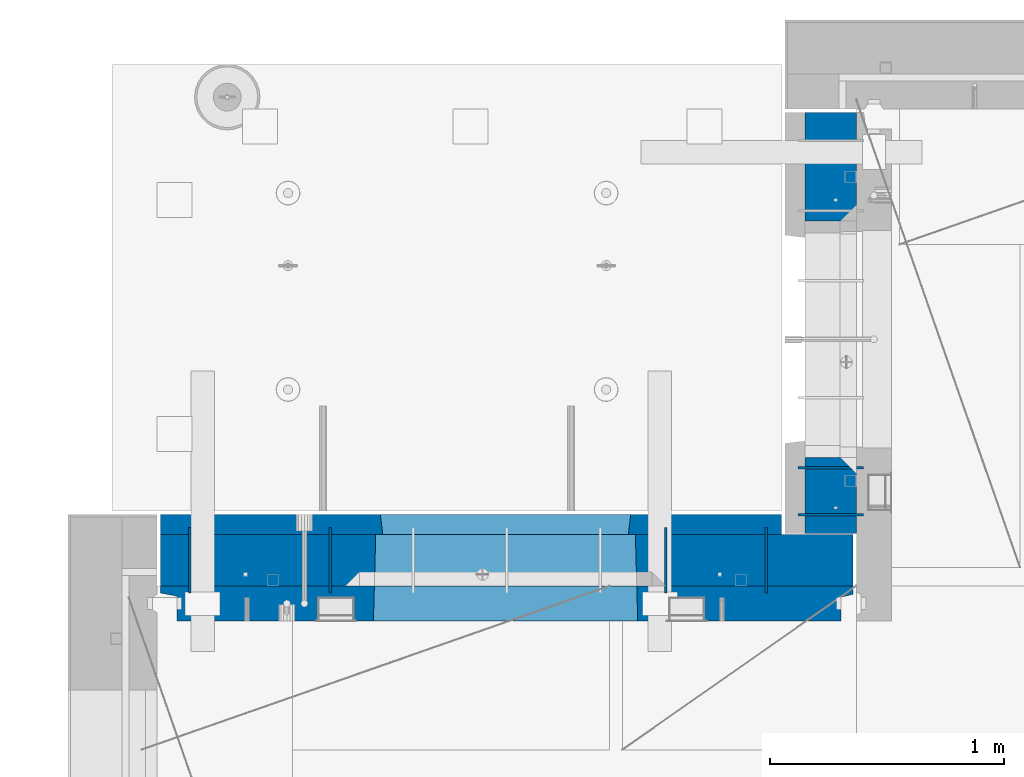
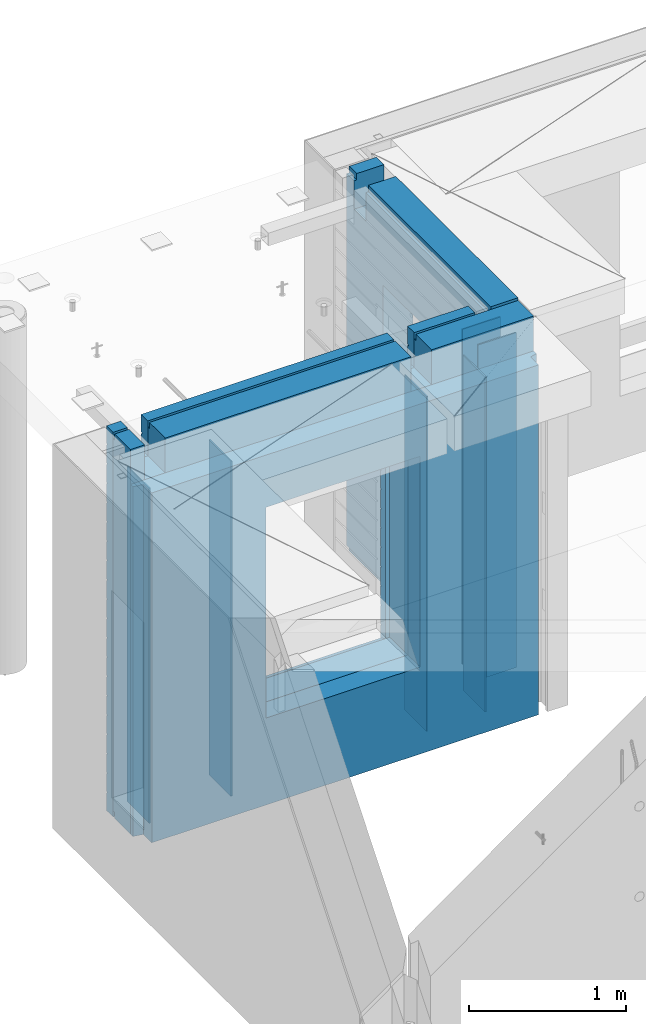
# One storey, part 201 of 309: 10 walls, 2 elements without a shape of their own.
"""IFC2X3 building model written with IfcOpenShell, lengths in millimetres."""

import ifcopenshell
import ifcopenshell.guid

model = None  # the IFC model being written
_history = None  # IfcOwnerHistory: only IFC2X3 demands one
_inside = {}  # id of a spatial element -> (the spatial element, [elements in it])
_under = {}  # id of a project, library or spatial element -> (it, [spatial elements below it])
_declared = {}  # id of a project -> (the project, [libraries it declares])
_typed = {}  # id of a type object -> (the type object, [elements of that type])
_made_of = {}  # id of a material, layer set ... -> (it, [elements and type objects made of it])


def new_model(schema):
    """Start an empty IFC model of exactly this schema.

    Asked for "IFC4X3", IfcOpenShell would pick the latest addendum, in which some entities
    have other attributes; the version numbers below select the first issue.
    IFC2X3 requires an IfcOwnerHistory on every rooted entity: one is made here for all.
    """
    global model, _history
    if schema == "IFC4X3":
        model = ifcopenshell.file(schema_version=(4, 3, 0, 0))
    else:
        model = ifcopenshell.file(schema=schema)
    _inside.clear()
    _under.clear()
    _declared.clear()
    _typed.clear()
    _made_of.clear()
    _history = None
    if model.schema == "IFC2X3":
        org = make("IfcOrganization", Name="unknown")
        user = make(
            "IfcPersonAndOrganization",
            ThePerson=make("IfcPerson", FamilyName="unknown"),
            TheOrganization=org,
        )
        app = make(
            "IfcApplication",
            ApplicationDeveloper=org,
            Version="unknown",
            ApplicationFullName="unknown",
            ApplicationIdentifier="unknown",
        )
        _history = make(
            "IfcOwnerHistory",
            OwningUser=user,
            OwningApplication=app,
            ChangeAction="ADDED",
            CreationDate=0,
        )
    return model


def make(cls, **values):
    """One entity of the class cls with the attributes given. An attribute that is None is left unset."""
    return model.create_entity(
        cls, **{name: value for name, value in values.items() if value is not None}
    )


def rooted(cls, **values):
    """An entity with a GlobalId (a new one), such as an element, a storey or a relation."""
    return make(cls, GlobalId=ifcopenshell.guid.new(), OwnerHistory=_history, **values)


def si_unit(unit_type, name, prefix=None):
    """IfcSIUnit, for example si_unit("LENGTHUNIT", "METRE", prefix="MILLI")."""
    return make("IfcSIUnit", UnitType=unit_type, Prefix=prefix, Name=name)


def assignment(units):
    """IfcUnitAssignment: the units of a project."""
    return None if units is None else make("IfcUnitAssignment", Units=units)


def point(xyz):
    """IfcCartesianPoint."""
    return None if xyz is None else make("IfcCartesianPoint", Coordinates=xyz)


def direction(xyz):
    """IfcDirection."""
    return None if xyz is None else make("IfcDirection", DirectionRatios=xyz)


def frame(location, z_axis=None, x_axis=None):
    """IfcAxis2Placement3D, a coordinate frame: its origin and axes. An axis left out is left unset."""
    return make(
        "IfcAxis2Placement3D",
        Location=point(location),
        Axis=direction(z_axis),
        RefDirection=direction(x_axis),
    )


def origin_with_axes():
    """The frame at (0, 0, 0) with the z axis (0, 0, 1) and the x axis (1, 0, 0) written out."""
    return frame((0.0, 0.0, 0.0), z_axis=(0.0, 0.0, 1.0), x_axis=(1.0, 0.0, 0.0))


def place(relative_to, where):
    """IfcLocalPlacement: puts the frame where relative to a parent placement (None: the world)."""
    return make(
        "IfcLocalPlacement", PlacementRelTo=relative_to, RelativePlacement=where
    )


def context(
    kind, dimensions, precision=None, world=None, true_north=None, identifier=None
):
    """IfcGeometricRepresentationContext, for example the 3D "Model" context."""
    return make(
        "IfcGeometricRepresentationContext",
        ContextIdentifier=identifier,
        ContextType=kind,
        CoordinateSpaceDimension=dimensions,
        Precision=precision,
        WorldCoordinateSystem=world,
        TrueNorth=true_north,
    )


def subcontext(parent, identifier, kind, view, scale=None):
    """IfcGeometricRepresentationSubContext, for example "Body" below "Model"."""
    return make(
        "IfcGeometricRepresentationSubContext",
        ContextIdentifier=identifier,
        ContextType=kind,
        ParentContext=parent,
        TargetScale=scale,
        TargetView=view,
    )


def project(units=None, contexts=None):
    """IfcProject with its units and contexts."""
    return rooted(
        "IfcProject",
        Name="project",
        RepresentationContexts=contexts,
        UnitsInContext=assignment(units),
    )


def spatial(cls, under=None, at=None, **own):
    """A site, building, storey or space (cls), placed at a placement, below another one or the project."""
    s = rooted(cls, ObjectPlacement=at, **own)
    if under is not None:
        _under.setdefault(under.id(), (under, []))[1].append(s)
    return s


def faces_of(points, faces, orient=None, outer=None):
    """IfcFace entities. A face is a list of loops; a loop is a list of indices into points, from 0.

    orient and outer hold one flag for each loop. By default every Orientation is true, the
    first loop of a face is its IfcFaceOuterBound and the others are IfcFaceBound.
    """
    made = []
    for i, loops in enumerate(faces):
        bounds = []
        for j, loop in enumerate(loops):
            is_outer = j == 0 if outer is None else outer[i][j]
            bounds.append(
                make(
                    "IfcFaceOuterBound" if is_outer else "IfcFaceBound",
                    Bound=make("IfcPolyLoop", Polygon=[points[k] for k in loop]),
                    Orientation=True if orient is None else orient[i][j],
                )
            )
        made.append(make("IfcFace", Bounds=bounds))
    return made


def faceted_brep(points, faces, orient=None, outer=None, voids=None):
    """IfcFacetedBrep: a solid bounded by flat faces; with voids (closed shells), ...WithVoids."""
    shared = [point(p) for p in points]
    hull = make("IfcClosedShell", CfsFaces=faces_of(shared, faces, orient, outer))
    if voids is None:
        return make("IfcFacetedBrep", Outer=hull)
    return make(
        "IfcFacetedBrepWithVoids",
        Outer=hull,
        Voids=[
            make(cls, CfsFaces=faces_of(shared, fs, o, b)) for cls, fs, o, b in voids
        ],
    )


def shape(context_of_items, identifier, shape_type, items):
    """IfcShapeRepresentation: the items that make up one representation, for example the "Body"."""
    return make(
        "IfcShapeRepresentation",
        ContextOfItems=context_of_items,
        RepresentationIdentifier=identifier,
        RepresentationType=shape_type,
        Items=items,
    )


def material(Name=None, Category=None):
    """IfcMaterial."""
    return make("IfcMaterial", Name=Name, Category=Category)


def made_of(thing, what):
    """Note that an element or type object is made of a material, layer set ...; save() writes the relation."""
    if what is not None:
        _made_of.setdefault(what.id(), (what, []))[1].append(thing)
    return thing


def type_object(cls, material=None, **own):
    """A type object (cls), such as IfcWallType, which elements share."""
    return made_of(rooted(cls, **own), material)


def element(
    cls,
    number,
    at=None,
    inside=None,
    cuts=None,
    type_object=None,
    material=None,
    context=None,
    identifier="Body",
    shape_type=None,
    held_by="IfcProductDefinitionShape",
    body=None,
    shapes=None,
    **own,
):
    """One element of the class cls, such as IfcWall. Its Tag is "e" and its number.

    at: its placement. inside: the storey or other place that contains it. cuts: it is an
    opening in that element (IfcRelVoidsElement). A single representation is given by context,
    identifier, shape_type and body (its items); several are given by shapes. held_by: the class
    of the entity that holds the representations. save() writes the other relations.
    """
    e = rooted(cls, Tag="e%d" % number, ObjectPlacement=at, **own)
    if body is not None:
        shapes = [shape(context, identifier, shape_type, body)]
    if shapes is not None:
        e.Representation = make(held_by, Representations=shapes)
    if inside is not None:
        _inside.setdefault(inside.id(), (inside, []))[1].append(e)
    if cuts is not None:
        rooted(
            "IfcRelVoidsElement", RelatingBuildingElement=cuts, RelatedOpeningElement=e
        )
    if type_object is not None:
        _typed.setdefault(type_object.id(), (type_object, []))[1].append(e)
    return made_of(e, material)


def aggregate(whole, parts):
    """IfcRelAggregates: a whole, such as a stair, and the parts it consists of."""
    return rooted("IfcRelAggregates", RelatingObject=whole, RelatedObjects=parts)


def save(model, path):
    """Write the relations noted so far, then the file.

    IfcRelAggregates (storeys below a building ...), IfcRelContainedInSpatialStructure (elements
    in a storey), IfcRelDefinesByType, IfcRelAssociatesMaterial and IfcRelDeclares: one each for
    every whole, place, type object, material and project.
    """
    for whole, parts in _under.values():
        aggregate(whole, parts)
    for where, things in _inside.values():
        rooted(
            "IfcRelContainedInSpatialStructure",
            RelatedElements=things,
            RelatingStructure=where,
        )
    for kind, things in _typed.values():
        rooted("IfcRelDefinesByType", RelatedObjects=things, RelatingType=kind)
    for what, things in _made_of.values():
        rooted("IfcRelAssociatesMaterial", RelatedObjects=things, RelatingMaterial=what)
    for by, libraries in _declared.values():
        rooted("IfcRelDeclares", RelatingContext=by, RelatedDefinitions=libraries)
    model.write(path)


model = new_model("IFC2X3")

# Units and contexts
model_context = context("Model", 3, precision=1e-05, world=origin_with_axes())
body_context = subcontext(model_context, "Body", "Model", "MODEL_VIEW")
ifc_project = project(units=[si_unit("LENGTHUNIT", "METRE", prefix="MILLI"), si_unit("AREAUNIT", "SQUARE_METRE"), si_unit("VOLUMEUNIT", "CUBIC_METRE"), si_unit("MASSUNIT", "GRAM", prefix="KILO"), si_unit("TIMEUNIT", "SECOND"), si_unit("PLANEANGLEUNIT", "RADIAN"), si_unit("SOLIDANGLEUNIT", "STERADIAN"), si_unit("THERMODYNAMICTEMPERATUREUNIT", "DEGREE_CELSIUS"), si_unit("LUMINOUSINTENSITYUNIT", "LUMEN")], contexts=[model_context])

# Site, building, storey
site_placement = place(None, origin_with_axes())
site = spatial("IfcSite", under=ifc_project, at=site_placement, CompositionType="ELEMENT")
building_placement = place(site_placement, origin_with_axes())
building = spatial("IfcBuilding", under=site, at=building_placement, CompositionType="ELEMENT")
storey_placement = place(building_placement, origin_with_axes())
storey = spatial("IfcBuildingStorey", under=building, at=storey_placement, Name="7", CompositionType="ELEMENT", Elevation=0.0)

# Assembly, wall
assembly_1_placement = place(storey_placement, origin_with_axes())
assembly_1 = element("IfcElementAssembly", 1, at=assembly_1_placement, inside=storey, AssemblyPlace="NOTDEFINED", PredefinedType="REINFORCEMENT_UNIT")
ifc_material_1 = material(Name="Undefined")
wall_type_1 = type_object("IfcWallType", PredefinedType="NOTDEFINED")
wall_1_placement = place(assembly_1_placement, frame((10605.0002441406, 20549.9951872276, 101115.0), z_axis=(0.0, 0.0, 1.0), x_axis=(0.0, 1.0, 0.0)))
wall_1 = element("IfcWall", 2, at=wall_1_placement, type_object=wall_type_1, material=ifc_material_1, Name="(PD)", context=body_context, shape_type="Brep", body=[
    faceted_brep([(0.0, 5.0, -1300.0), (0.0, 5.0, 1300.0), (280.0, 5.0, 1300.0), (280.0, 5.0, -1300.0), (0.0, -5.0, 1300.0), (280.0, -5.0, 1300.0), (0.0, -5.0, -1300.0), (280.0, -5.0, -1300.0)], [[[0, 1, 2, 3]], [[1, 4, 5, 2]], [[4, 6, 7, 5]], [[6, 0, 3, 7]], [[5, 7, 3, 2]], [[6, 4, 1, 0]]]),
])

# Assembly, walls
assembly_2_placement = place(storey_placement, origin_with_axes())
assembly_2 = element("IfcElementAssembly", 3, at=assembly_2_placement, inside=storey, AssemblyPlace="NOTDEFINED", PredefinedType="REINFORCEMENT_UNIT")
wall_2_placement = place(assembly_2_placement, frame((11020.0, 20885.0002441406, 101115.0), z_axis=(0.0, 0.0, 1.0), x_axis=(-1.0, 3.00000001838171e-08, 0.0)))
wall_2 = element("IfcWall", 4, at=wall_2_placement, type_object=wall_type_1, material=ifc_material_1, Name="(PD)", context=body_context, shape_type="Brep", body=[
    faceted_brep([(0.0, 5.0, -1300.0), (0.0, 5.0, 1300.0), (280.0, 5.0, 1300.0), (280.0, 5.0, -1300.0), (0.0, -5.0, 1300.0), (280.0, -5.0, 1300.0), (0.0, -5.0, -1300.0), (280.0, -5.0, -1300.0)], [[[0, 1, 2, 3]], [[1, 4, 5, 2]], [[4, 6, 7, 5]], [[6, 0, 3, 7]], [[5, 7, 3, 2]], [[6, 4, 1, 0]]]),
])
wall_3_placement = place(assembly_2_placement, frame((11020.0, 21085.0002441406, 101115.0), z_axis=(0.0, 0.0, 1.0), x_axis=(-1.0, 3.00000001838171e-08, 0.0)))
wall_3 = element("IfcWall", 5, at=wall_3_placement, type_object=wall_type_1, material=ifc_material_1, Name="(PD)", context=body_context, shape_type="Brep", body=[
    faceted_brep([(0.0, 5.0, -1300.0), (0.0, 5.0, 1300.0), (280.0, 5.0, 1300.0), (280.0, 5.0, -1300.0), (0.0, -5.0, 1300.0), (280.0, -5.0, 1300.0), (0.0, -5.0, -1300.0), (280.0, -5.0, -1300.0)], [[[0, 1, 2, 3]], [[1, 4, 5, 2]], [[4, 6, 7, 5]], [[6, 0, 3, 7]], [[5, 7, 3, 2]], [[6, 4, 1, 0]]]),
])

# Wall
wall_4_placement = place(assembly_1_placement, frame((8140.00024414063, 20549.9951872276, 101115.0), z_axis=(0.0, 0.0, 1.0), x_axis=(0.0, 1.0, 0.0)))
wall_4 = element("IfcWall", 6, at=wall_4_placement, type_object=wall_type_1, material=ifc_material_1, Name="(PD)", context=body_context, shape_type="Brep", body=[
    faceted_brep([(0.0, 5.0, -1300.0), (0.0, 5.0, 1300.0), (280.0, 5.0, 1300.0), (280.0, 5.0, -1300.0), (0.0, -5.0, 1300.0), (280.0, -5.0, 1300.0), (0.0, -5.0, -1300.0), (280.0, -5.0, -1300.0)], [[[0, 1, 2, 3]], [[1, 4, 5, 2]], [[4, 6, 7, 5]], [[6, 0, 3, 7]], [[5, 7, 3, 2]], [[6, 4, 1, 0]]]),
])

wall_5_placement = place(assembly_1_placement, frame((8740.00024414063, 20549.9951872276, 101115.0), z_axis=(0.0, 0.0, 1.0), x_axis=(0.0, 1.0, 0.0)))
wall_5 = element("IfcWall", 7, at=wall_5_placement, type_object=wall_type_1, material=ifc_material_1, Name="(PD)", context=body_context, shape_type="Brep", body=[
    faceted_brep([(0.0, 5.0, -1300.0), (0.0, 5.0, 1300.0), (280.0, 5.0, 1300.0), (280.0, 5.0, -1300.0), (0.0, -5.0, 1300.0), (280.0, -5.0, 1300.0), (0.0, -5.0, -1300.0), (280.0, -5.0, -1300.0)], [[[0, 1, 2, 3]], [[1, 4, 5, 2]], [[4, 6, 7, 5]], [[6, 0, 3, 7]], [[5, 7, 3, 2]], [[6, 4, 1, 0]]]),
])

wall_6_placement = place(assembly_1_placement, frame((10175.0002441406, 20549.9951872276, 101115.0), z_axis=(0.0, 0.0, 1.0), x_axis=(0.0, 1.0, 0.0)))
wall_6 = element("IfcWall", 8, at=wall_6_placement, type_object=wall_type_1, material=ifc_material_1, Name="(PD)", context=body_context, shape_type="Brep", body=[
    faceted_brep([(0.0, 5.0, -1300.0), (0.0, 5.0, 1300.0), (280.0, 5.0, 1300.0), (280.0, 5.0, -1300.0), (0.0, -5.0, 1300.0), (280.0, -5.0, 1300.0), (0.0, -5.0, -1300.0), (280.0, -5.0, -1300.0)], [[[0, 1, 2, 3]], [[1, 4, 5, 2]], [[4, 6, 7, 5]], [[6, 0, 3, 7]], [[5, 7, 3, 2]], [[6, 4, 1, 0]]]),
])

ifc_material_2 = material(Name="COS5gt")
wall_type_2 = type_object("IfcWallType", PredefinedType="NOTDEFINED")
wall_7_placement = place(assembly_2_placement, frame((10880.0, 20805.0, 101247.5), z_axis=(0.0, 0.0, 1.0), x_axis=(0.0, 1.0, 0.0)))
wall_7 = element("IfcWall", 9, at=wall_7_placement, type_object=wall_type_2, material=ifc_material_2, context=body_context, shape_type="Brep", body=[
    faceted_brep([(1800.0, -110.0, 1492.5), (1800.0, 90.0, 1492.5), (1705.0, 90.0, 1492.5), (1705.0, -110.0, 1492.5), (1800.0, 90.0, 1442.5), (1800.0, 110.0, 1442.5), (1705.0, 110.0, 1442.5), (1705.0, 90.0, 1442.5), (0.0, 110.0, 1442.5), (0.0, 90.0, 1442.5), (1555.0, 90.0, 1442.5), (1555.0, 110.0, 1442.5), (0.0, -110.0, -1492.5), (0.0, 90.0, -1492.5), (325.000271651108, 90.0, -1492.5), (325.000271651108, -110.0, -1492.5), (0.0, 90.0, -1442.5), (325.000271651108, 90.0, -1442.5), (0.0, -110.0, 1492.5), (0.0, 90.0, 1492.5), (0.0, 110.0, -1442.5), (325.000271651108, 110.0, -1442.5), (325.000271651108, 110.0, 857.5), (325.000271651108, -110.0, 857.5), (1335.00027165111, 110.0, 857.5), (1335.00027165111, -110.0, 857.5), (1555.0, 110.0, 1222.5), (1705.0, 110.0, 1222.5), (1800.0, 110.0, -1442.5), (1335.00027165111, 110.0, -1442.5), (1800.0, 90.0, -1442.5), (1800.0, 90.0, -1492.5), (1335.00027165111, 90.0, -1492.5), (1335.00027165111, 90.0, -1442.5), (1800.0, -110.0, -1492.5), (1335.00027165111, -110.0, -1492.5), (1705.0, -110.0, 1222.5), (1555.0, -110.0, 1222.5), (1555.0, -110.0, 1492.5), (1555.0, 90.0, 1492.5)], [[[0, 1, 2, 3]], [[4, 5, 6, 7]], [[8, 9, 10, 11]], [[12, 13, 14, 15]], [[13, 16, 17, 14]], [[13, 12, 18, 19, 9, 8, 20, 16]], [[16, 20, 21, 17]], [[15, 14, 17, 21, 22, 23]], [[23, 22, 24, 25]], [[21, 20, 8, 11, 26, 27, 6, 5, 28, 29, 24, 22]], [[30, 31, 32, 33]], [[28, 30, 33, 29]], [[5, 4, 1, 0, 34, 31, 30, 28]], [[31, 34, 35, 32]], [[25, 24, 29, 33, 32, 35]], [[34, 0, 3, 36, 37, 38, 18, 12, 15, 23, 25, 35]], [[19, 18, 38, 39]], [[9, 19, 39, 10]], [[38, 37, 26, 11, 10, 39]], [[36, 27, 26, 37]], [[3, 2, 7, 6, 27, 36]], [[1, 4, 7, 2]]]),
])

aggregate(assembly_2, [wall_2, wall_3, wall_7])

wall_8_placement = place(assembly_1_placement, frame((8000.0, 20689.9951872276, 101247.5), z_axis=(0.0, 0.0, 1.0), x_axis=(1.0, 0.0, 0.0)))
wall_8 = element("IfcWall", 10, at=wall_8_placement, type_object=wall_type_2, material=ifc_material_2, context=body_context, shape_type="Brep", body=[
    faceted_brep([(15.0, 110.0, 1442.5), (15.0, 90.0, 1442.5), (119.999999999998, 90.0, 1442.5), (119.999999999998, 110.0, 1442.5), (15.0, 90.0, 1492.5), (119.999999999998, 90.0, 1492.5), (15.0, -110.0, 1492.5), (119.999999999998, -110.0, 1492.5), (119.999999999998, -110.0, 1222.5), (119.999999999998, 110.0, 1222.5), (269.999999999998, -110.0, 1222.5), (269.999999999998, 110.0, 1222.5), (269.999999999998, 110.0, 1442.5), (269.999999999998, 90.0, 1442.5), (2075.0, 90.0, 1442.5), (2075.0, 110.0, 1442.5), (269.999999999998, 90.0, 1492.5), (2075.0, 90.0, 1492.5), (269.999999999998, -110.0, 1492.5), (2075.0, -110.0, 1492.5), (2075.0, -110.000000000004, 1222.5), (2075.0, 109.999999999996, 1222.5), (2225.0, -110.000000000004, 1222.5), (2225.0, 109.999999999996, 1222.5), (2975.0, -110.0, 1492.5), (2975.0, 90.0, 1492.5), (2225.0, 90.0, 1492.5), (2225.0, -110.0, 1492.5), (2975.0, -110.0, -1492.5), (15.0, -110.0, -1492.5), (15.0, 90.0, -1492.5), (2975.0, 90.0, -1492.5), (2975.0, 110.0, 1442.5), (2975.0, 90.0, 1442.5), (2975.0, 90.0, -1442.5), (2975.0, 110.0, -1442.5), (2225.0, 110.0, 1442.5), (2225.0, 90.0, 1442.5), (929.055290664681, -110.000000000004, -813.445945945947), (929.055290664681, -110.000000000004, 813.445945945947), (2050.94718255657, -110.000000000004, 813.445945945947), (2050.94718255657, -110.000000000004, -813.445945945947), (935.001236610628, 110.0, -802.5), (935.001236610628, 110.0, 807.5), (935.001236610628, 110.0, -807.5), (2045.00123661063, 110.0, -807.5), (2015.00123661063, 110.0, -807.5), (965.001236610628, 110.0, -807.5), (2045.00123661063, 110.0, 807.5), (2045.00123661063, 110.0, -802.5), (15.0, 110.0, -1442.5), (15.0, 90.0, -1442.5)], [[[0, 1, 2, 3]], [[1, 4, 5, 2]], [[4, 6, 7, 5]], [[3, 2, 5, 7, 8, 9]], [[9, 8, 10, 11]], [[12, 13, 14, 15]], [[13, 16, 17, 14]], [[12, 11, 10, 18, 16, 13]], [[16, 18, 19, 17]], [[15, 14, 17, 19, 20, 21]], [[21, 20, 22, 23]], [[24, 25, 26, 27]], [[28, 29, 30, 31]], [[32, 33, 25, 24, 28, 31, 34, 35]], [[33, 32, 36, 37]], [[25, 33, 37, 26]], [[36, 23, 22, 27, 26, 37]], [[20, 19, 18, 10, 8, 7, 6, 29, 28, 24, 27, 22], [38, 39, 40, 41]], [[42, 43, 39, 38, 44]], [[41, 45, 46, 47, 44, 38]], [[40, 48, 49, 45, 41]], [[39, 43, 48, 40]], [[32, 35, 50, 0, 3, 9, 11, 12, 15, 21, 23, 36], [42, 44, 47, 46, 45, 49, 48, 43]], [[30, 29, 6, 4, 1, 0, 50, 51]], [[35, 34, 51, 50]], [[31, 30, 51, 34]]]),
])

ifc_material_3 = material(Name="CONCRETE/C30/37")
wall_type_3 = type_object("IfcWallType", PredefinedType="NOTDEFINED")
wall_9_placement = place(assembly_1_placement, frame((8000.0, 20842.4951872276, 101247.5), z_axis=(0.0, 0.0, 1.0), x_axis=(1.0, 0.0, 0.0)))
wall_9 = element("IfcWall", 11, at=wall_9_placement, type_object=wall_type_3, material=ifc_material_3, context=body_context, shape_type="Brep", body=[
    faceted_brep([(2670.0, -42.5, 1492.5), (2670.0, 42.5, 1492.5), (2225.0, 42.5, 1492.5), (2225.0, -42.5, 1492.5), (2670.0, 42.4999992431622, 1356.99999988925), (2225.0, 42.4999993700148, 1356.99999988925), (2670.0, 32.4999991126933, 1355.00000040043), (2670.0, 32.4999992506928, 1344.9999999992), (2225.0, 32.4999992506928, 1344.9999999992), (2225.0, 32.4999991126933, 1355.00000040043), (2670.0, 42.4999996036859, 1342.99999994476), (2225.0, 42.4999996701117, 1342.99999994476), (2670.0, 42.4999993831079, 892.999999944761), (15.0, 42.5, 892.999999944761), (15.0, 32.4999992506928, 894.9999999992), (2670.0, 32.4999992506928, 894.9999999992), (15.0, 32.4999991126933, 905.000000400425), (2670.0, 32.4999991126933, 905.000000400425), (2670.0, 42.4999992431622, 906.999999889245), (15.0, 42.5, 906.999999889245), (15.0, 42.5, 1042.99999994476), (2670.0, 42.4999994189602, 1042.99999994476), (15.0, 32.4999992506928, 1044.9999999992), (2670.0, 32.4999992506928, 1044.9999999992), (15.0, 32.4999991126933, 1055.00000040043), (2670.0, 32.4999991126933, 1055.00000040043), (2670.0, 42.4999992431622, 1056.99999988925), (15.0, 42.5, 1056.99999988925), (15.0, 42.5, 1192.99999994476), (2670.0, 42.4999994795107, 1192.99999994476), (15.0000000000009, 32.4999992506928, 1194.9999999992), (2670.0, 32.4999992506928, 1194.9999999992), (15.0000000000009, 32.4999991126933, 1205.00000040043), (2670.0, 32.4999991126933, 1205.00000040043), (2670.0, 42.4999992431622, 1206.99999988925), (15.0, 42.5, 1206.99999988925), (15.0, 32.4999992506928, 1344.9999999992), (15.0, 32.4999991126933, 1355.00000040043), (119.999999999998, 32.4999991126933, 1355.00000040043), (119.999999999998, 32.4999992506928, 1344.9999999992), (15.0, 42.5, 1342.99999994476), (119.999999999998, 42.4999999843276, 1342.99999994476), (269.999999999998, 32.4999992506928, 1344.9999999992), (269.999999999998, 32.4999991126933, 1355.00000040043), (2075.0, 32.4999991126933, 1355.00000040043), (2075.0, 32.4999992506928, 1344.9999999992), (269.999999999998, 42.4999999619358, 1342.99999994476), (2075.0, 42.4999996925035, 1342.99999994476), (119.999999999998, 42.4999999076099, 1222.5), (269.999999999998, 42.4999998750354, 1222.5), (2075.0, 42.4999994593163, 1222.5), (2225.0, 42.4999994264763, 1222.5), (119.999999999998, -42.5, 1222.5), (269.999999999998, -42.5, 1222.5), (269.999999999998, 42.5, 1492.5), (269.999999999998, 42.4999999273095, 1356.99999988925), (269.999999999998, -42.5, 1492.5), (2075.0, -42.5, 1492.5), (2075.0, 42.5, 1492.5), (2075.0, 42.4999994127757, 1356.99999988925), (2075.0, -42.5000000000036, 1222.5), (2225.0, -42.5000000000036, 1222.5), (2670.0, -42.5, -1492.5), (2670.0, 42.5, -1492.5), (2670.0, 42.5, -1357.00000005524), (2670.0, 32.4999992506928, -1355.0000000008), (2670.0, 32.4999991126933, -1344.99999959957), (2670.0, 42.4999992431622, -1343.00000011075), (2670.0, 42.4999992794619, -1207.00000005524), (2670.0, 32.4999992506928, -1205.0000000008), (2670.0, 32.4999991126933, -1194.99999959957), (2670.0, 42.4999992431622, -1193.00000011075), (2670.0, 42.4999992814919, -1057.00000005524), (2670.0, 32.4999992506928, -1055.0000000008), (2670.0, 32.4999991126933, -1044.99999959957), (2670.0, 42.4999992431622, -1043.00000011075), (2670.0, 42.4999992837584, -907.000000055239), (2670.0, 32.4999992506928, -905.0000000008), (2670.0, 32.4999991126933, -894.999999599575), (2670.0, 42.4999992431622, -893.000000110755), (2670.0, 42.4999992863086, -757.000000055239), (2670.0, 32.4999992506928, -755.0000000008), (2670.0, 32.4999991126933, -744.999999599575), (2670.0, 42.4999992431622, -743.000000110755), (2670.0, 42.4999992892044, -607.000000055239), (2670.0, 32.4999992506928, -605.0000000008), (2670.0, 32.4999991126933, -594.999999599575), (2670.0, 42.4999992431622, -593.000000110755), (2670.0, 42.4999992925186, -457.000000055239), (2670.0, 32.4999992506928, -455.0000000008), (2670.0, 32.4999991126933, -444.999999599575), (2670.0, 42.4999992431622, -443.000000110755), (2670.0, 42.4999992963421, -307.000000055239), (2670.0, 32.4999992506928, -305.0000000008), (2670.0, 32.4999991126933, -294.999999599575), (2670.0, 42.4999992431622, -293.000000110755), (2670.0, 42.4999993008096, -157.000000055239), (2670.0, 32.4999992506928, -155.0000000008), (2670.0, 32.4999991126933, -144.999999599575), (2670.0, 42.4999992431622, -143.000000110755), (2670.0, 42.4999993060956, -7.00000005523907), (2670.0, 32.4999992506928, -5.00000000080036), (2670.0, 32.4999991126933, 5.00000040042505), (2670.0, 42.4999992431622, 6.99999988924537), (2670.0, 42.4999993124511, 142.999999944761), (2670.0, 32.4999992506928, 144.9999999992), (2670.0, 32.4999991126933, 155.000000400425), (2670.0, 42.4999992431622, 156.999999889245), (2670.0, 42.4999993202327, 292.999999944761), (2670.0, 32.4999992506928, 294.9999999992), (2670.0, 32.4999991126933, 305.000000400425), (2670.0, 42.4999992431622, 306.999999889245), (2670.0, 42.4999993299862, 442.999999944761), (2670.0, 32.4999992506928, 444.9999999992), (2670.0, 32.4999991126933, 455.000000400425), (2670.0, 42.4999992431622, 456.999999889245), (2670.0, 42.4999993425627, 592.999999944761), (2670.0, 32.4999992506928, 594.9999999992), (2670.0, 32.4999991126933, 605.000000400425), (2670.0, 42.4999992431622, 606.999999889245), (2670.0, 42.4999993594029, 742.999999944761), (2670.0, 32.4999992506928, 744.9999999992), (2670.0, 32.4999991126933, 755.000000400425), (2670.0, 42.4999992431622, 756.999999889245), (15.0, -42.5, -1492.5), (15.0, 42.5, -1492.5), (15.0, 42.5, -1357.00000005524), (15.0, 32.4999992506928, -1355.0000000008), (15.0, 32.4999991126933, -1344.99999959957), (15.0, 42.5, -1343.00000011075), (15.0, 42.5, -1207.00000005524), (15.0, 32.4999992506928, -1205.0000000008), (15.0, 32.4999991126933, -1194.99999959957), (15.0, 42.5, -1193.00000011075), (15.0, 42.5, -1057.00000005524), (15.0, 32.4999992506928, -1055.0000000008), (15.0, 32.4999991126933, -1044.99999959957), (15.0, 42.5, -1043.00000011075), (15.0, 42.5, -907.000000055239), (15.0000000000009, 32.4999992506928, -905.0000000008), (15.0000000000009, 32.4999991126933, -894.999999599575), (15.0, 42.5, -893.000000110755), (15.0, 32.4999991126933, 755.000000400425), (15.0, 42.5, 756.999999889245), (955.001236610628, 42.499999732041, 756.999999889245), (956.177707303252, 32.4999991126933, 755.000000400425), (15.0, 32.4999992506928, 744.9999999992), (956.177707287017, 32.4999992506928, 744.9999999992), (15.0, 42.5, 742.999999944761), (955.001236610628, 42.4999997731975, 742.999999944761), (15.0, 42.5, 606.999999889245), (955.001236610628, 42.499999732041, 606.999999889245), (15.0, 32.4999991126933, 605.000000400425), (956.177707303252, 32.4999991126933, 605.000000400425), (15.0, 32.4999992506928, 594.9999999992), (956.177707287017, 32.4999992506928, 594.9999999992), (15.0, 42.5, 592.999999944761), (955.001236610628, 42.4999997672348, 592.999999944761), (15.0, 42.5, 456.999999889245), (955.001236610628, 42.499999732041, 456.999999889245), (15.0, 32.4999991126933, 455.000000400425), (956.177707303252, 32.4999991126933, 455.000000400425), (15.0, 32.4999992506928, 444.9999999992), (956.177707287017, 32.4999992506928, 444.9999999992), (15.0, 42.5, 442.999999944761), (955.001236610628, 42.499999762782, 442.999999944761), (15.0, 42.5, 306.999999889245), (955.001236610628, 42.499999732041, 306.999999889245), (15.0, 32.4999991126933, 305.000000400425), (956.177707303252, 32.4999991126933, 305.000000400425), (15.0, 32.4999992506928, 294.9999999992), (956.177707287017, 32.4999992506928, 294.9999999992), (15.0, 42.5, 292.999999944761), (955.001236610628, 42.4999997593295, 292.999999944761), (15.0, 42.5, 156.999999889245), (955.001236610628, 42.499999732041, 156.999999889245), (15.0000000000009, 32.4999991126933, 155.000000400425), (956.177707303254, 32.4999991126933, 155.000000400425), (15.0000000000009, 32.4999992506928, 144.9999999992), (956.177707287017, 32.4999992506928, 144.9999999992), (15.0, 42.5, 142.999999944761), (955.001236610628, 42.4999997565719, 142.999999944761), (15.0, 42.5, 6.99999988924537), (955.001236610628, 42.499999732041, 6.99999988924537), (14.9999999999991, 32.4999991126933, 5.00000040042505), (956.177707303254, 32.4999991126933, 5.00000040042505), (14.9999999999991, 32.4999992506928, -5.00000000080036), (956.177707287017, 32.4999992506928, -5.00000000080036), (15.0, 42.5, -7.00000005523907), (955.001236610628, 42.4999997543237, -7.00000005523907), (15.0, 42.5, -143.000000110755), (955.001236610628, 42.499999732041, -143.000000110755), (15.0000000000009, 32.4999991126933, -144.999999599575), (956.177707303254, 32.4999991126933, -144.999999599575), (15.0000000000009, 32.4999992506928, -155.0000000008), (956.177707287017, 32.4999992506928, -155.0000000008), (15.0, 42.5, -157.000000055239), (955.001236610628, 42.4999997524537, -157.000000055239), (15.0, 42.5, -293.000000110755), (955.001236610628, 42.499999732041, -293.000000110755), (15.0, 32.4999991126933, -294.999999599575), (956.177707303252, 32.4999991126933, -294.999999599575), (15.0, 32.4999992506928, -305.0000000008), (956.177707287017, 32.4999992506928, -305.0000000008), (15.0, 42.5, -307.000000055239), (955.001236610628, 42.4999997508712, -307.000000055239), (15.0, 42.5, -443.000000110755), (955.001236610628, 42.499999732041, -443.000000110755), (15.0000000000009, 32.4999991126933, -444.999999599575), (956.177707303254, 32.4999991126933, -444.999999599575), (15.0000000000009, 32.4999992506928, -455.0000000008), (956.177707287017, 32.4999992506928, -455.0000000008), (15.0, 42.5, -457.000000055239), (955.001236610628, 42.4999997495179, -457.000000055239), (15.0, 42.5, -593.000000110755), (955.001236610628, 42.499999732041, -593.000000110755), (15.0, 32.4999991126933, -594.999999599575), (956.177707303252, 32.4999991126933, -594.999999599575), (15.0, 32.4999992506928, -605.0000000008), (956.177707287017, 32.4999992506928, -605.0000000008), (15.0, 42.5, -607.000000055239), (955.001236610628, 42.4999997483428, -607.000000055239), (15.0, 42.5, -743.000000110755), (955.001236610628, 42.499999732041, -743.000000110755), (15.0, 32.4999991126933, -744.999999599575), (956.177707303252, 32.4999991126933, -744.999999599575), (15.0, 32.4999992506928, -755.0000000008), (956.177707287017, 32.4999992506928, -755.0000000008), (15.0, 42.5, -757.000000055239), (955.001236610628, 42.4999997473169, -757.000000055239), (955.001236610628, 42.5, -857.5), (965.001236610628, -42.5, -807.5), (2015.00123661063, -42.5, -807.5), (2025.00123661063, 42.5, -857.5), (2025.00123661063, 42.499999459691, -757.000000055239), (2023.82476593424, 32.4999992506928, -755.0000000008), (2023.824765918, 32.4999991126933, -744.999999599575), (2025.00123661063, 42.4999994270256, -743.000000110755), (2025.00123661063, 42.4999994618847, -607.000000055239), (2023.82476593424, 32.4999992506928, -605.0000000008), (2023.824765918, 32.4999991126933, -594.999999599575), (2025.00123661063, 42.4999994270256, -593.000000110755), (2025.00123661063, 42.4999994643913, -457.000000055239), (2023.82476593424, 32.4999992506928, -455.0000000008), (2023.824765918, 32.4999991126933, -444.999999599575), (2025.00123661063, 42.4999994270256, -443.000000110755), (2025.00123661063, 42.4999994672871, -307.000000055239), (2023.82476593424, 32.4999992506928, -305.0000000008), (2023.824765918, 32.4999991126933, -294.999999599575), (2025.00123661063, 42.4999994270256, -293.000000110755), (2025.00123661063, 42.4999994706704, -157.000000055239), (2023.82476593424, 32.4999992506928, -155.0000000008), (2023.824765918, 32.4999991126933, -144.999999599575), (2025.00123661063, 42.4999994270256, -143.000000110755), (2025.00123661063, 42.4999994746722, -7.00000005523907), (2023.82476593424, 32.4999992506928, -5.00000000080036), (2023.824765918, 32.4999991126933, 5.00000040042505), (2025.00123661063, 42.4999994270256, 6.99999988924537), (2025.00123661063, 42.4999994794816, 142.999999944761), (2023.82476593424, 32.4999992506928, 144.9999999992), (2023.824765918, 32.4999991126933, 155.000000400425), (2025.00123661063, 42.4999994270256, 156.999999889245), (2025.00123661063, 42.4999994853752, 292.999999944761), (2023.82476593424, 32.4999992506928, 294.9999999992), (2023.824765918, 32.4999991126933, 305.000000400425), (2025.00123661063, 42.4999994270256, 306.999999889245), (2025.00123661063, 42.4999994927566, 442.999999944761), (2023.82476593424, 32.4999992506928, 444.9999999992), (2023.824765918, 32.4999991126933, 455.000000400425), (2025.00123661063, 42.4999994270256, 456.999999889245), (2025.00123661063, 42.4999995022772, 592.999999944761), (2023.82476593424, 32.4999992506928, 594.9999999992), (2023.824765918, 32.4999991126933, 605.000000400425), (2025.00123661063, 42.4999994270256, 606.999999889245), (2025.00123661063, 42.4999995150283, 742.999999944761), (2023.82476593424, 32.4999992506928, 744.9999999992), (2023.824765918, 32.4999991126933, 755.000000400425), (2025.00123661063, 42.4999994270256, 756.999999889245), (965.001236610628, 42.5, 782.5), (955.001236610628, 42.5, 782.5), (2025.00123661063, 42.5, 782.5), (2015.00123661063, 42.5, 782.5), (965.001236610628, -42.5, 782.5), (965.001236610628, -42.5, 787.5), (2015.00123661063, -42.5, 787.5), (2015.00123661063, -42.5, 782.5), (119.999999999998, -42.5, 1492.5), (15.0, -42.5, 1492.5), (15.0, 42.5, 1492.5), (119.999999999998, 42.5, 1492.5), (15.0, 42.5, 1356.99999988925), (119.999999999998, 42.4999999700703, 1356.99999988925)], [[[0, 1, 2, 3]], [[1, 4, 5, 2]], [[6, 7, 8, 9]], [[7, 10, 11, 8]], [[12, 13, 14, 15]], [[15, 14, 16, 17]], [[18, 17, 16, 19]], [[18, 19, 20, 21]], [[21, 20, 22, 23]], [[23, 22, 24, 25]], [[26, 25, 24, 27]], [[26, 27, 28, 29]], [[29, 28, 30, 31]], [[31, 30, 32, 33]], [[34, 33, 32, 35]], [[36, 37, 38, 39]], [[40, 36, 39, 41]], [[42, 43, 44, 45]], [[46, 42, 45, 47]], [[10, 34, 35, 40, 41, 48, 49, 46, 47, 50, 51, 11]], [[48, 52, 53, 49]], [[54, 55, 43, 42, 46, 49, 53, 56]], [[54, 56, 57, 58]], [[55, 54, 58, 59]], [[43, 55, 59, 44]], [[58, 57, 60, 50, 47, 45, 44, 59]], [[50, 60, 61, 51]], [[2, 5, 9, 8, 11, 51, 61, 3]], [[4, 6, 9, 5]], [[1, 0, 62, 63, 64, 65, 66, 67, 68, 69, 70, 71, 72, 73, 74, 75, 76, 77, 78, 79, 80, 81, 82, 83, 84, 85, 86, 87, 88, 89, 90, 91, 92, 93, 94, 95, 96, 97, 98, 99, 100, 101, 102, 103, 104, 105, 106, 107, 108, 109, 110, 111, 112, 113, 114, 115, 116, 117, 118, 119, 120, 121, 122, 123, 12, 15, 17, 18, 21, 23, 25, 26, 29, 31, 33, 34, 10, 7, 6, 4]], [[124, 125, 63, 62]], [[63, 125, 126, 64]], [[64, 126, 127, 65]], [[65, 127, 128, 66]], [[67, 66, 128, 129]], [[67, 129, 130, 68]], [[68, 130, 131, 69]], [[69, 131, 132, 70]], [[71, 70, 132, 133]], [[71, 133, 134, 72]], [[72, 134, 135, 73]], [[73, 135, 136, 74]], [[75, 74, 136, 137]], [[75, 137, 138, 76]], [[76, 138, 139, 77]], [[77, 139, 140, 78]], [[79, 78, 140, 141]], [[142, 143, 144, 145]], [[146, 142, 145, 147]], [[148, 146, 147, 149]], [[150, 148, 149, 151]], [[152, 150, 151, 153]], [[154, 152, 153, 155]], [[156, 154, 155, 157]], [[158, 156, 157, 159]], [[160, 158, 159, 161]], [[162, 160, 161, 163]], [[164, 162, 163, 165]], [[166, 164, 165, 167]], [[168, 166, 167, 169]], [[170, 168, 169, 171]], [[172, 170, 171, 173]], [[174, 172, 173, 175]], [[176, 174, 175, 177]], [[178, 176, 177, 179]], [[180, 178, 179, 181]], [[182, 180, 181, 183]], [[184, 182, 183, 185]], [[186, 184, 185, 187]], [[188, 186, 187, 189]], [[190, 188, 189, 191]], [[192, 190, 191, 193]], [[194, 192, 193, 195]], [[196, 194, 195, 197]], [[198, 196, 197, 199]], [[200, 198, 199, 201]], [[202, 200, 201, 203]], [[204, 202, 203, 205]], [[206, 204, 205, 207]], [[208, 206, 207, 209]], [[210, 208, 209, 211]], [[212, 210, 211, 213]], [[214, 212, 213, 215]], [[216, 214, 215, 217]], [[218, 216, 217, 219]], [[220, 218, 219, 221]], [[222, 220, 221, 223]], [[224, 222, 223, 225]], [[226, 224, 225, 227]], [[228, 226, 227, 229]], [[230, 231, 232, 233]], [[80, 79, 141, 228, 229, 230, 233, 234]], [[81, 80, 234, 235]], [[82, 81, 235, 236]], [[83, 82, 236, 237]], [[84, 83, 237, 238]], [[85, 84, 238, 239]], [[86, 85, 239, 240]], [[87, 86, 240, 241]], [[88, 87, 241, 242]], [[89, 88, 242, 243]], [[90, 89, 243, 244]], [[91, 90, 244, 245]], [[92, 91, 245, 246]], [[93, 92, 246, 247]], [[94, 93, 247, 248]], [[95, 94, 248, 249]], [[96, 95, 249, 250]], [[97, 96, 250, 251]], [[98, 97, 251, 252]], [[99, 98, 252, 253]], [[100, 99, 253, 254]], [[101, 100, 254, 255]], [[102, 101, 255, 256]], [[103, 102, 256, 257]], [[104, 103, 257, 258]], [[105, 104, 258, 259]], [[106, 105, 259, 260]], [[107, 106, 260, 261]], [[108, 107, 261, 262]], [[109, 108, 262, 263]], [[110, 109, 263, 264]], [[111, 110, 264, 265]], [[112, 111, 265, 266]], [[113, 112, 266, 267]], [[114, 113, 267, 268]], [[115, 114, 268, 269]], [[116, 115, 269, 270]], [[117, 116, 270, 271]], [[118, 117, 271, 272]], [[119, 118, 272, 273]], [[120, 119, 273, 274]], [[121, 120, 274, 275]], [[122, 121, 275, 276]], [[123, 122, 276, 277]], [[278, 279, 144, 143, 13, 12, 123, 277, 280, 281]], [[282, 231, 230, 229, 227, 225, 223, 221, 219, 217, 215, 213, 211, 209, 207, 205, 203, 201, 199, 197, 195, 193, 191, 189, 187, 185, 183, 181, 179, 177, 175, 173, 171, 169, 167, 165, 163, 161, 159, 157, 155, 153, 151, 149, 147, 145, 144, 279, 283]], [[278, 281, 280, 284, 283, 279]], [[277, 276, 275, 274, 273, 272, 271, 270, 269, 268, 267, 266, 265, 264, 263, 262, 261, 260, 259, 258, 257, 256, 255, 254, 253, 252, 251, 250, 249, 248, 247, 246, 245, 244, 243, 242, 241, 240, 239, 238, 237, 236, 235, 234, 233, 232, 285, 284, 280]], [[60, 57, 56, 53, 52, 286, 287, 124, 62, 0, 3, 61], [232, 231, 282, 283, 284, 285]], [[288, 287, 286, 289]], [[36, 40, 35, 32, 30, 28, 27, 24, 22, 20, 19, 16, 14, 13, 143, 142, 146, 148, 150, 152, 154, 156, 158, 160, 162, 164, 166, 168, 170, 172, 174, 176, 178, 180, 182, 184, 186, 188, 190, 192, 194, 196, 198, 200, 202, 204, 206, 208, 210, 212, 214, 216, 218, 220, 222, 224, 226, 228, 141, 140, 139, 138, 137, 136, 135, 134, 133, 132, 131, 130, 129, 128, 127, 126, 125, 124, 287, 288, 290, 37]], [[37, 290, 291, 38]], [[289, 286, 52, 48, 41, 39, 38, 291]], [[290, 288, 289, 291]]]),
])

ifc_material_4 = material(Name="CONCRETE/C25/30")
wall_type_4 = type_object("IfcWallType", PredefinedType="NOTDEFINED")
wall_10_placement = place(assembly_1_placement, frame((8000.0, 20504.9951872276, 101112.5), z_axis=(0.0, 0.0, 1.0), x_axis=(1.0, 0.0, 0.0)))
wall_10 = element("IfcWall", 12, at=wall_10_placement, type_object=wall_type_4, material=ifc_material_4, context=body_context, shape_type="Brep", body=[
    faceted_brep([(2925.0, -75.0, 1357.5), (2925.0, -75.0, -1357.5), (2925.0, 27.0, -1357.5), (2925.0, 27.0, 1357.5), (2975.0, 75.0, 1357.5), (15.0, 75.0, 1357.5), (15.0, 45.0, 1357.5), (85.0, 32.0, 1357.5), (85.0, -75.0, 1357.5), (2975.0, 40.0, 1357.5), (85.0, 32.0, -1357.5), (85.0, -75.0, -1357.5), (15.0, 45.0, -1357.5), (15.0, 75.0, -1357.5), (2975.0, 75.0, -1357.5), (2975.0, 40.0, -1357.5), (925.001236610628, -75.0, 952.5), (929.055290664681, 75.0, 948.445945945947), (2050.94718255657, 75.0, 948.445945945947), (2055.00123661063, -75.0, 952.5), (929.055290664681, 75.0, -678.445945945947), (2050.94718255657, 75.0, -678.445945945947), (2055.00123661063, -75.0, -682.5), (925.001236610628, -75.0, -682.5)], [[[0, 1, 2, 3]], [[4, 5, 6, 7, 8, 0, 3, 9]], [[7, 10, 11, 8]], [[6, 12, 10, 7]], [[5, 13, 12, 6]], [[1, 11, 10, 12, 13, 14, 15, 2]], [[9, 3, 2, 15]], [[14, 4, 9, 15]], [[16, 17, 18, 19]], [[13, 5, 4, 14], [20, 21, 18, 17]], [[19, 18, 21, 22]], [[8, 11, 1, 0], [23, 16, 19, 22]], [[17, 16, 23, 20]], [[22, 21, 20, 23]]]),
])

aggregate(assembly_1, [wall_1, wall_4, wall_5, wall_6, wall_9, wall_8, wall_10])

save(model, "model.ifc")
